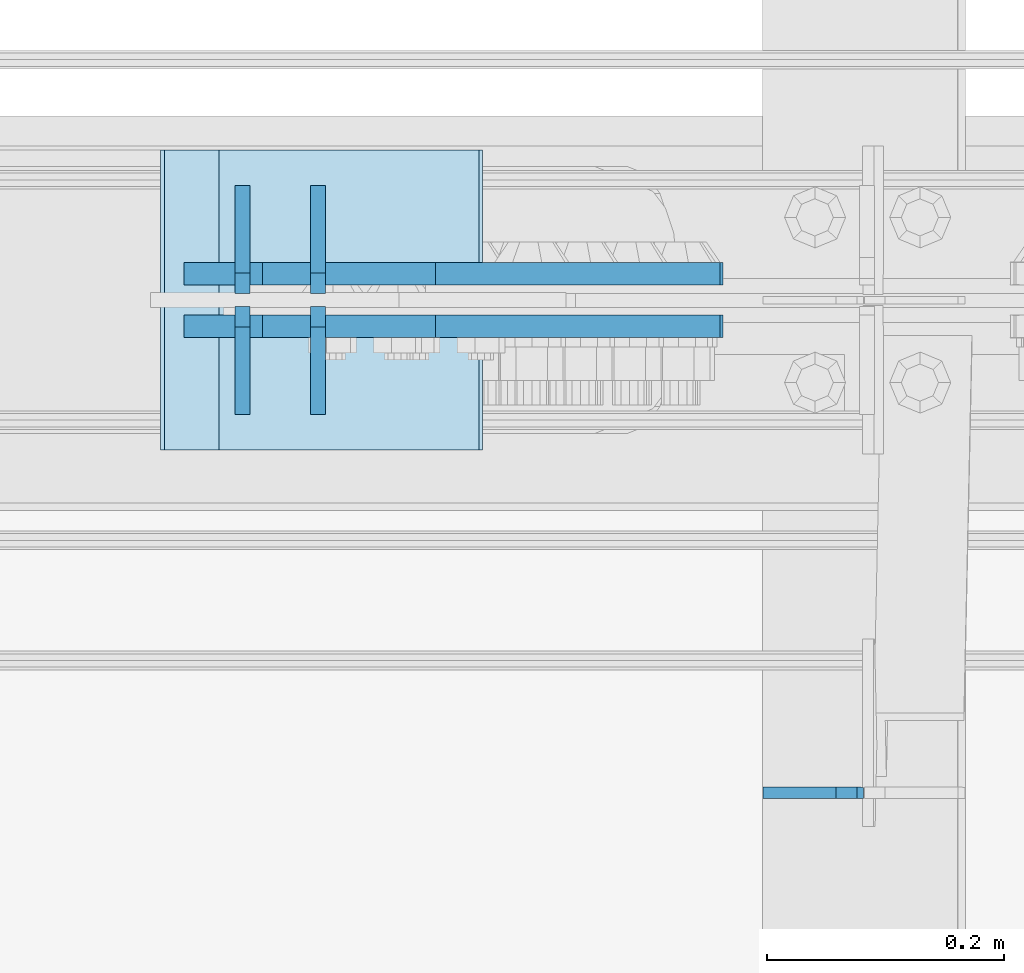
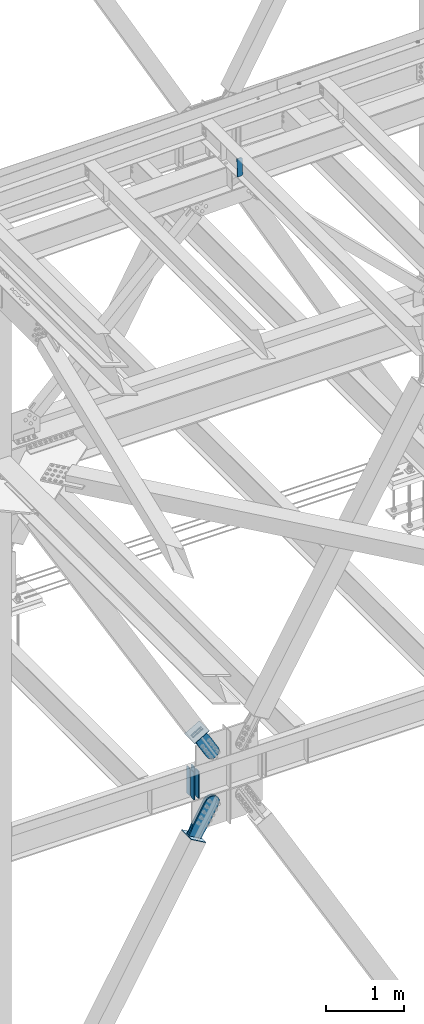
# One storey, part 3469 of 3843: 11 plates, 8 elements without a shape of their own.
"""IFC2X3 building model written with IfcOpenShell, lengths in millimetres."""

from ifc_helpers import new_model, si_unit, frame, origin_with_axes, place, context, subcontext, project, spatial, faceted_brep, material, type_object, element, aggregate, save


model = new_model("IFC2X3")

# Units and contexts
model_context = context("Model", 3, precision=1e-05, world=origin_with_axes())
body_context = subcontext(model_context, "Body", "Model", "MODEL_VIEW")
ifc_project = project(units=[si_unit("LENGTHUNIT", "METRE", prefix="MILLI"), si_unit("AREAUNIT", "SQUARE_METRE"), si_unit("VOLUMEUNIT", "CUBIC_METRE"), si_unit("MASSUNIT", "GRAM", prefix="KILO"), si_unit("TIMEUNIT", "SECOND"), si_unit("PLANEANGLEUNIT", "RADIAN"), si_unit("SOLIDANGLEUNIT", "STERADIAN"), si_unit("THERMODYNAMICTEMPERATUREUNIT", "DEGREE_CELSIUS"), si_unit("LUMINOUSINTENSITYUNIT", "LUMEN")], contexts=[model_context])

# Site, building, storey
site_placement = place(None, origin_with_axes())
site = spatial("IfcSite", under=ifc_project, at=site_placement, CompositionType="ELEMENT")
building_placement = place(site_placement, origin_with_axes())
building = spatial("IfcBuilding", under=site, at=building_placement, Name="Undefined", CompositionType="ELEMENT")
storey_placement = place(building_placement, origin_with_axes())
storey = spatial("IfcBuildingStorey", under=building, at=storey_placement, Name="Undefined", CompositionType="ELEMENT", Elevation=0.0)

# Assembly, plates
assembly_1_placement = place(storey_placement, origin_with_axes())
assembly_1 = element("IfcElementAssembly", 1, at=assembly_1_placement, inside=storey, Name="BEAM", AssemblyPlace="NOTDEFINED", PredefinedType="RIGID_FRAME")
ifc_material_1 = material(Name="STEEL/A572-50")
plate_type_1 = type_object("IfcPlateType", PredefinedType="NOTDEFINED")
plate_1_placement = place(assembly_1_placement, frame((51934.7908973036, 92220.25625, 35990.2125), z_axis=(0.0, 1.0, 0.0), x_axis=(0.0, 0.0, 1.0)))
plate_1 = element("IfcPlate", 2, at=plate_1_placement, type_object=plate_type_1, material=ifc_material_1, Name="CB_BEAM", context=body_context, shape_type="Brep", body=[
    faceted_brep([(0.0, -6.34999999999854, 17.4624996185303), (0.0, -6.34999999999854, 91.28125), (0.0, 6.34999999999854, 91.28125), (0.0, 6.34999999999854, 17.4624996185303), (425.449999999997, -6.34999999999854, 91.28125), (425.449999999997, 6.34999999999854, 91.28125), (425.449999999997, -6.34999999999854, 17.4624996185303), (425.449999999997, 6.34999999999854, 17.4624996185303), (407.987500381467, -6.34999999999854, 0.0), (407.987500381467, 6.34999999999854, 0.0), (17.4624996185303, -6.34999999999854, 0.0), (17.4624996185303, 6.34999999999854, 0.0)], [[[0, 1, 2, 3]], [[1, 4, 5, 2]], [[4, 6, 7, 5]], [[6, 8, 9, 7]], [[8, 10, 11, 9]], [[10, 0, 3, 11]], [[5, 7, 9, 11, 3, 2]], [[10, 8, 6, 4, 1, 0]]]),
])
plate_2_placement = place(assembly_1_placement, frame((51934.7908973036, 92209.14375, 35990.2125), z_axis=(0.0, -1.0, 0.0), x_axis=(0.0, 0.0, 1.0)))
plate_2 = element("IfcPlate", 3, at=plate_2_placement, type_object=plate_type_1, material=ifc_material_1, Name="CB_BEAM", context=body_context, shape_type="Brep", body=[
    faceted_brep([(0.0, -6.34999999999854, 17.4624996185303), (0.0, -6.34999999999854, 91.28125), (0.0, 6.34999999999854, 91.28125), (0.0, 6.34999999999854, 17.4624996185303), (425.449999999997, -6.34999999999854, 91.28125), (425.449999999997, 6.34999999999854, 91.28125), (425.449999999997, -6.34999999999854, 17.4624996185303), (425.449999999997, 6.34999999999854, 17.4624996185303), (407.987500381467, -6.34999999999854, 0.0), (407.987500381467, 6.34999999999854, 0.0), (17.4624996185303, -6.34999999999854, 0.0), (17.4624996185303, 6.34999999999854, 0.0)], [[[0, 1, 2, 3]], [[1, 4, 5, 2]], [[4, 6, 7, 5]], [[6, 8, 9, 7]], [[8, 10, 11, 9]], [[10, 0, 3, 11]], [[5, 7, 9, 11, 3, 2]], [[10, 8, 6, 4, 1, 0]]]),
])
plate_3_placement = place(assembly_1_placement, frame((51998.6362771378, 92220.25625, 35990.2125), z_axis=(0.0, 1.0, 0.0), x_axis=(0.0, 0.0, 1.0)))
plate_3 = element("IfcPlate", 4, at=plate_3_placement, type_object=plate_type_1, material=ifc_material_1, Name="CB_BEAM", context=body_context, shape_type="Brep", body=[
    faceted_brep([(0.0, -6.34999999999854, 17.4624996185303), (0.0, -6.34999999999854, 91.28125), (0.0, 6.34999999999854, 91.28125), (0.0, 6.34999999999854, 17.4624996185303), (425.449999999997, -6.34999999999854, 91.28125), (425.449999999997, 6.34999999999854, 91.28125), (425.449999999997, -6.34999999999854, 17.4624996185303), (425.449999999997, 6.34999999999854, 17.4624996185303), (407.987500381467, -6.34999999999854, 0.0), (407.987500381467, 6.34999999999854, 0.0), (17.4624996185303, -6.34999999999854, 0.0), (17.4624996185303, 6.34999999999854, 0.0)], [[[0, 1, 2, 3]], [[1, 4, 5, 2]], [[4, 6, 7, 5]], [[6, 8, 9, 7]], [[8, 10, 11, 9]], [[10, 0, 3, 11]], [[5, 7, 9, 11, 3, 2]], [[10, 8, 6, 4, 1, 0]]]),
])
plate_4_placement = place(assembly_1_placement, frame((51998.6362771378, 92209.14375, 35990.2125), z_axis=(0.0, -1.0, 0.0), x_axis=(0.0, 0.0, 1.0)))
plate_4 = element("IfcPlate", 5, at=plate_4_placement, type_object=plate_type_1, material=ifc_material_1, Name="CB_BEAM", context=body_context, shape_type="Brep", body=[
    faceted_brep([(0.0, -6.34999999999854, 17.4624996185303), (0.0, -6.34999999999854, 91.28125), (0.0, 6.34999999999854, 91.28125), (0.0, 6.34999999999854, 17.4624996185303), (425.449999999997, -6.34999999999854, 91.28125), (425.449999999997, 6.34999999999854, 91.28125), (425.449999999997, -6.34999999999854, 17.4624996185303), (425.449999999997, 6.34999999999854, 17.4624996185303), (407.987500381467, -6.34999999999854, 0.0), (407.987500381467, 6.34999999999854, 0.0), (17.4624996185303, -6.34999999999854, 0.0), (17.4624996185303, 6.34999999999854, 0.0)], [[[0, 1, 2, 3]], [[1, 4, 5, 2]], [[4, 6, 7, 5]], [[6, 8, 9, 7]], [[8, 10, 11, 9]], [[10, 0, 3, 11]], [[5, 7, 9, 11, 3, 2]], [[10, 8, 6, 4, 1, 0]]]),
])
aggregate(assembly_1, [plate_1, plate_2, plate_3, plate_4])

# Assembly, plate
assembly_2_placement = place(storey_placement, origin_with_axes())
assembly_2 = element("IfcElementAssembly", 6, at=assembly_2_placement, inside=storey, AssemblyPlace="NOTDEFINED", PredefinedType="RIGID_FRAME")
ifc_material_2 = material(Name="STEEL/A36")
plate_type_2 = type_object("IfcPlateType", PredefinedType="NOTDEFINED")
plate_5_placement = place(assembly_2_placement, frame((52098.1148412432, 92236.925, 37003.8066377777), z_axis=(-0.865635480884958, 0.0, -0.500674758933449), x_axis=(0.500674758933455, 0.0, -0.865635480884955)))
plate_5 = element("IfcPlate", 7, at=plate_5_placement, type_object=plate_type_2, material=ifc_material_2, context=body_context, shape_type="Brep", body=[
    faceted_brep([(0.0, -9.52500000000146, 0.0), (-2.16823536902666e-09, -9.52499999999418, 169.022957228546), (-2.16823536902666e-09, 9.52499999999418, 169.022957228546), (0.0, 9.52500000000146, 0.0), (69.8499999974956, -9.52499999999418, 169.02295722875), (69.8499999974956, 9.52499999999418, 169.02295722875), (171.449999996829, -9.52499999999418, 181.348978614493), (171.449999996829, 9.52499999999418, 181.348978614493), (434.579297661258, -9.52499999999418, 181.348978615235), (434.579297661258, 9.52499999999418, 181.348978615235), (471.63740512668, -9.52499999999418, 173.977662728823), (471.63740512668, 9.52499999999418, 173.977662728823), (503.053751663178, -9.52499999999418, 152.985931091971), (503.053751663178, 9.52499999999418, 152.985931091971), (524.045483300536, -9.52499999999418, 121.569584555793), (524.045483300536, 9.52499999999418, 121.569584555793), (531.416799187516, -9.52499999999418, 84.511480142959), (531.416799187516, 9.52499999999418, 84.511480142959), (524.0454833013, -9.52499999999418, 47.4533726770169), (524.0454833013, 9.52499999999418, 47.4533726770169), (503.053751664252, -9.52499999999418, 16.0370261400676), (503.053751664252, 9.52499999999418, 16.0370261400676), (471.63740512763, -9.52499999999418, -4.95470549746824), (471.63740512763, 9.52499999999418, -4.95470549746824), (434.579299189239, -9.52499999999418, -12.3260213842586), (434.579299189239, 9.52499999999418, -12.3260213842586), (171.44999999931, -9.52499999999418, -12.3260213849862), (171.44999999931, 9.52499999999418, -12.3260213849862), (69.8499999979995, -9.52499999999418, -4.00177668780088e-10), (69.8499999979995, 9.52499999999418, -4.00177668780088e-10)], [[[0, 1, 2, 3]], [[1, 4, 5, 2]], [[4, 6, 7, 5]], [[6, 8, 9, 7]], [[8, 10, 11, 9]], [[10, 12, 13, 11]], [[12, 14, 15, 13]], [[14, 16, 17, 15]], [[16, 18, 19, 17]], [[18, 20, 21, 19]], [[20, 22, 23, 21]], [[22, 24, 25, 23]], [[24, 26, 27, 25]], [[26, 28, 29, 27]], [[28, 0, 3, 29]], [[5, 7, 9, 11, 13, 15, 17, 19, 21, 23, 25, 27, 29, 3, 2]], [[28, 26, 24, 22, 20, 18, 16, 14, 12, 10, 8, 6, 4, 1, 0]]]),
])
aggregate(assembly_2, [plate_5])

assembly_3_placement = place(storey_placement, origin_with_axes())
assembly_3 = element("IfcElementAssembly", 8, at=assembly_3_placement, inside=storey, AssemblyPlace="NOTDEFINED", PredefinedType="RIGID_FRAME")
plate_6_placement = place(assembly_3_placement, frame((52098.1148412432, 92192.475, 37003.8066377777), z_axis=(-0.865635480884958, 0.0, -0.500674758933449), x_axis=(0.500674758933455, 0.0, -0.865635480884955)))
plate_6 = element("IfcPlate", 9, at=plate_6_placement, type_object=plate_type_2, material=ifc_material_2, context=body_context, shape_type="Brep", body=[
    faceted_brep([(0.0, -9.52500000000146, 0.0), (-2.16823536902666e-09, -9.52499999999418, 169.022957228546), (-2.16823536902666e-09, 9.52499999999418, 169.022957228546), (0.0, 9.52500000000146, 0.0), (69.8499999974956, -9.52499999999418, 169.02295722875), (69.8499999974956, 9.52499999999418, 169.02295722875), (171.449999996829, -9.52499999999418, 181.348978614493), (171.449999996829, 9.52499999999418, 181.348978614493), (434.579297661258, -9.52499999999418, 181.348978615235), (434.579297661258, 9.52499999999418, 181.348978615235), (471.63740512668, -9.52499999999418, 173.977662728823), (471.63740512668, 9.52499999999418, 173.977662728823), (503.053751663178, -9.52499999999418, 152.985931091971), (503.053751663178, 9.52499999999418, 152.985931091971), (524.045483300536, -9.52499999999418, 121.569584555793), (524.045483300536, 9.52499999999418, 121.569584555793), (531.416799187516, -9.52499999999418, 84.511480142959), (531.416799187516, 9.52499999999418, 84.511480142959), (524.0454833013, -9.52499999999418, 47.4533726770169), (524.0454833013, 9.52499999999418, 47.4533726770169), (503.053751664252, -9.52499999999418, 16.0370261400676), (503.053751664252, 9.52499999999418, 16.0370261400676), (471.63740512763, -9.52499999999418, -4.95470549746824), (471.63740512763, 9.52499999999418, -4.95470549746824), (434.579299189239, -9.52499999999418, -12.3260213842586), (434.579299189239, 9.52499999999418, -12.3260213842586), (171.44999999931, -9.52499999999418, -12.3260213849862), (171.44999999931, 9.52499999999418, -12.3260213849862), (69.8499999979995, -9.52499999999418, -4.00177668780088e-10), (69.8499999979995, 9.52499999999418, -4.00177668780088e-10)], [[[0, 1, 2, 3]], [[1, 4, 5, 2]], [[4, 6, 7, 5]], [[6, 8, 9, 7]], [[8, 10, 11, 9]], [[10, 12, 13, 11]], [[12, 14, 15, 13]], [[14, 16, 17, 15]], [[16, 18, 19, 17]], [[18, 20, 21, 19]], [[20, 22, 23, 21]], [[22, 24, 25, 23]], [[24, 26, 27, 25]], [[26, 28, 29, 27]], [[28, 0, 3, 29]], [[5, 7, 9, 11, 13, 15, 17, 19, 21, 23, 25, 27, 29, 3, 2]], [[28, 26, 24, 22, 20, 18, 16, 14, 12, 10, 8, 6, 4, 1, 0]]]),
])
aggregate(assembly_3, [plate_6])

assembly_4_placement = place(storey_placement, origin_with_axes())
assembly_4 = element("IfcElementAssembly", 10, at=assembly_4_placement, inside=storey, Name="Plate", AssemblyPlace="NOTDEFINED", PredefinedType="RIGID_FRAME")
plate_type_3 = type_object("IfcPlateType", PredefinedType="NOTDEFINED")
plate_7_placement = place(assembly_4_placement, frame((52087.8039287679, 92087.7, 35289.3652960417), z_axis=(-0.868187207007649, 0.0, 0.496236812004368), x_axis=(0.0, 1.0, 0.0)))
plate_7 = element("IfcPlate", 11, at=plate_7_placement, type_object=plate_type_3, material=ifc_material_2, Name="Plate", context=body_context, shape_type="Brep", body=[
    faceted_brep([(0.0, -3.17499999999927, 0.0), (0.0, -3.17499999965185, 254.000000005151), (0.0, 3.17500000035216, 254.000000005166), (0.0, 3.17499999999927, 0.0), (254.0, -3.17499999965185, 254.000000005151), (254.0, 3.17500000035216, 254.000000005166), (254.0, -3.17500000000291, 0.0), (254.0, 3.17499999999927, 1.45519152283669e-11)], [[[0, 1, 2, 3]], [[1, 4, 5, 2]], [[4, 6, 7, 5]], [[6, 0, 3, 7]], [[5, 7, 3, 2]], [[6, 4, 1, 0]]]),
])
aggregate(assembly_4, [plate_7])

assembly_5_placement = place(storey_placement, origin_with_axes())
assembly_5 = element("IfcElementAssembly", 12, at=assembly_5_placement, inside=storey, Name="Plate", AssemblyPlace="NOTDEFINED", PredefinedType="RIGID_FRAME")
plate_8_placement = place(assembly_5_placement, frame((51916.6126430985, 92341.7, 36895.1597865597), z_axis=(0.865635480884955, 0.0, 0.500674758933454), x_axis=(0.0, -1.0, 0.0)))
plate_8 = element("IfcPlate", 13, at=plate_8_placement, type_object=plate_type_3, material=ifc_material_2, Name="Plate", context=body_context, shape_type="Brep", body=[
    faceted_brep([(0.0, -3.17499999999927, 0.0), (0.0, -3.17499999965185, 254.000000005151), (0.0, 3.17500000035216, 254.000000005166), (0.0, 3.17499999999927, 0.0), (254.0, -3.17499999965185, 254.000000005151), (254.0, 3.17500000035216, 254.000000005166), (254.0, -3.17500000000291, 0.0), (254.0, 3.17499999999927, 1.45519152283669e-11)], [[[0, 1, 2, 3]], [[1, 4, 5, 2]], [[4, 6, 7, 5]], [[6, 0, 3, 7]], [[5, 7, 3, 2]], [[6, 4, 1, 0]]]),
])
aggregate(assembly_5, [plate_8])

assembly_6_placement = place(storey_placement, origin_with_axes())
assembly_6 = element("IfcElementAssembly", 14, at=assembly_6_placement, inside=storey, AssemblyPlace="NOTDEFINED", PredefinedType="RIGID_FRAME")
plate_type_4 = type_object("IfcPlateType", PredefinedType="NOTDEFINED")
plate_9_placement = place(assembly_6_placement, frame((52066.2542918536, 92236.925, 35298.0255516423), z_axis=(-0.868187207007649, 0.0, 0.496236812004368), x_axis=(0.496236812004375, 0.0, 0.868187207007645)))
plate_9 = element("IfcPlate", 15, at=plate_9_placement, type_object=plate_type_4, material=ifc_material_2, context=body_context, shape_type="Brep", body=[
    faceted_brep([(0.0, -9.52500000000146, 0.0), (-1.45519152283669e-11, -9.52499999999418, 207.986686767843), (-1.45519152283669e-11, 9.52499999999418, 207.986686767843), (0.0, 9.52500000000146, 0.0), (69.8499999996129, -9.52499999999418, 207.986686767857), (69.8499999996129, 9.52499999999418, 207.986686767857), (171.449999999044, -9.52499999999418, 216.705843383315), (171.449999999044, 9.52499999999418, 216.705843383315), (511.019864338588, -9.52499999999418, 216.705843383315), (511.019864338588, 9.52499999999418, 216.705843383315), (554.153071292923, -9.52499999999418, 208.126115075342), (554.153071292923, 9.52499999999418, 208.126115075342), (590.719638491966, -9.52499999999418, 183.693116010902), (590.719638491966, 9.52499999999418, 183.693116010902), (615.152637556399, -9.52499999999418, 147.126548811866), (615.152637556399, 9.52499999999418, 147.126548811866), (623.732365864373, -9.52499999999418, 103.993344910348), (623.732365864373, 9.52499999999418, 103.993344910348), (615.152637556399, -9.52499999999418, 60.8601379559914), (615.152637556399, 9.52499999999418, 60.8601379559914), (590.719638491966, -9.52499999999418, 24.2935707569559), (590.719638491966, 9.52499999999418, 24.2935707569559), (554.153071292923, -9.52499999999418, -0.139428307476919), (554.153071292923, 9.52499999999418, -0.139428307476919), (511.01986586499, -9.52499999999418, -8.71915661544335), (511.01986586499, 9.52499999999418, -8.71915661544335), (171.449999999051, -9.52499999999418, -8.71915661547246), (171.449999999051, 9.52499999999418, -8.71915661547246), (69.8499999979995, -9.52499999999418, -4.00177668780088e-10), (69.8499999979995, 9.52499999999418, -4.00177668780088e-10)], [[[0, 1, 2, 3]], [[1, 4, 5, 2]], [[4, 6, 7, 5]], [[6, 8, 9, 7]], [[8, 10, 11, 9]], [[10, 12, 13, 11]], [[12, 14, 15, 13]], [[14, 16, 17, 15]], [[16, 18, 19, 17]], [[18, 20, 21, 19]], [[20, 22, 23, 21]], [[22, 24, 25, 23]], [[24, 26, 27, 25]], [[26, 28, 29, 27]], [[28, 0, 3, 29]], [[5, 7, 9, 11, 13, 15, 17, 19, 21, 23, 25, 27, 29, 3, 2]], [[28, 26, 24, 22, 20, 18, 16, 14, 12, 10, 8, 6, 4, 1, 0]]]),
])
aggregate(assembly_6, [plate_9])

assembly_7_placement = place(storey_placement, origin_with_axes())
assembly_7 = element("IfcElementAssembly", 16, at=assembly_7_placement, inside=storey, AssemblyPlace="NOTDEFINED", PredefinedType="RIGID_FRAME")
plate_10_placement = place(assembly_7_placement, frame((52066.2542918536, 92192.475, 35298.0255516423), z_axis=(-0.868187207007649, 0.0, 0.496236812004368), x_axis=(0.496236812004375, 0.0, 0.868187207007645)))
plate_10 = element("IfcPlate", 17, at=plate_10_placement, type_object=plate_type_4, material=ifc_material_2, context=body_context, shape_type="Brep", body=[
    faceted_brep([(0.0, -9.52500000000146, 0.0), (-1.45519152283669e-11, -9.52499999999418, 207.986686767843), (-1.45519152283669e-11, 9.52499999999418, 207.986686767843), (0.0, 9.52500000000146, 0.0), (69.8499999996129, -9.52499999999418, 207.986686767857), (69.8499999996129, 9.52499999999418, 207.986686767857), (171.449999999044, -9.52499999999418, 216.705843383315), (171.449999999044, 9.52499999999418, 216.705843383315), (511.019864338588, -9.52499999999418, 216.705843383315), (511.019864338588, 9.52499999999418, 216.705843383315), (554.153071292923, -9.52499999999418, 208.126115075342), (554.153071292923, 9.52499999999418, 208.126115075342), (590.719638491966, -9.52499999999418, 183.693116010902), (590.719638491966, 9.52499999999418, 183.693116010902), (615.152637556399, -9.52499999999418, 147.126548811866), (615.152637556399, 9.52499999999418, 147.126548811866), (623.732365864373, -9.52499999999418, 103.993344910348), (623.732365864373, 9.52499999999418, 103.993344910348), (615.152637556399, -9.52499999999418, 60.8601379559914), (615.152637556399, 9.52499999999418, 60.8601379559914), (590.719638491966, -9.52499999999418, 24.2935707569559), (590.719638491966, 9.52499999999418, 24.2935707569559), (554.153071292923, -9.52499999999418, -0.139428307476919), (554.153071292923, 9.52499999999418, -0.139428307476919), (511.01986586499, -9.52499999999418, -8.71915661544335), (511.01986586499, 9.52499999999418, -8.71915661544335), (171.449999999051, -9.52499999999418, -8.71915661547246), (171.449999999051, 9.52499999999418, -8.71915661547246), (69.8499999979995, -9.52499999999418, -4.00177668780088e-10), (69.8499999979995, 9.52499999999418, -4.00177668780088e-10)], [[[0, 1, 2, 3]], [[1, 4, 5, 2]], [[4, 6, 7, 5]], [[6, 8, 9, 7]], [[8, 10, 11, 9]], [[10, 12, 13, 11]], [[12, 14, 15, 13]], [[14, 16, 17, 15]], [[16, 18, 19, 17]], [[18, 20, 21, 19]], [[20, 22, 23, 21]], [[22, 24, 25, 23]], [[24, 26, 27, 25]], [[26, 28, 29, 27]], [[28, 0, 3, 29]], [[5, 7, 9, 11, 13, 15, 17, 19, 21, 23, 25, 27, 29, 3, 2]], [[28, 26, 24, 22, 20, 18, 16, 14, 12, 10, 8, 6, 4, 1, 0]]]),
])
aggregate(assembly_7, [plate_10])

assembly_8_placement = place(storey_placement, origin_with_axes())
assembly_8 = element("IfcElementAssembly", 18, at=assembly_8_placement, inside=storey, Name="BEAM", AssemblyPlace="NOTDEFINED", PredefinedType="RIGID_FRAME")
plate_type_5 = type_object("IfcPlateType", PredefinedType="NOTDEFINED")
plate_11_placement = place(assembly_8_placement, frame((52460.2906576283, 91797.9045772154, 45766.4413629769), z_axis=(-0.0211520979608104, 0.000867023000348128, 0.999775893399602), x_axis=(-0.999776269348226, -1.83429999838905e-05, -0.0211520900073297)))
plate_11 = element("IfcPlate", 19, at=plate_11_placement, type_object=plate_type_5, material=ifc_material_1, Name="STIFFENER", context=body_context, shape_type="Brep", body=[
    faceted_brep([(-1.45519152283669e-11, -4.76250000000073, 17.4624996184939), (-3.34694050252438e-10, -4.76250000000073, 271.462500379137), (-3.34694050252438e-10, 4.76250000000073, 271.462500379137), (-1.45519152283669e-11, 4.76250000000073, 17.4624996184939), (17.4624996182974, -4.76250000000073, 288.924999997646), (17.4624996182974, 4.76250000000073, 288.924999997646), (79.3749999983193, -4.762500000812, 288.924999996729), (79.3749999982974, 4.76249999915308, 288.924999996751), (79.3749999995416, -4.76250000040454, 1.96450855582952e-10), (79.3749999995271, 4.76249999956053, 2.11002770811319e-10), (17.4624996186321, -4.76250000000073, 7.27595761418343e-12), (17.4624996186321, 4.76250000000073, 7.27595761418343e-12)], [[[0, 1, 2, 3]], [[1, 4, 5, 2]], [[4, 6, 7, 5]], [[6, 8, 9, 7]], [[8, 10, 11, 9]], [[10, 0, 3, 11]], [[5, 7, 9, 11, 3, 2]], [[10, 8, 6, 4, 1, 0]]]),
])
aggregate(assembly_8, [plate_11])

save(model, "model.ifc")
